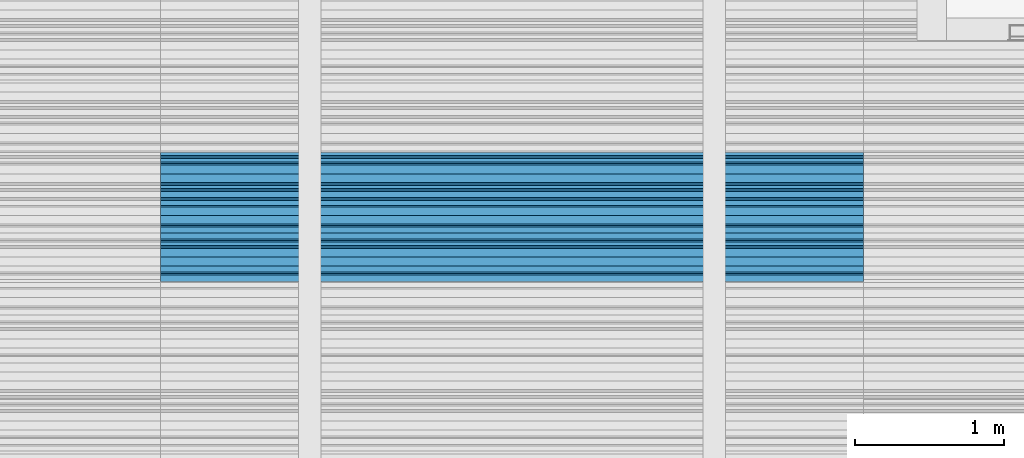
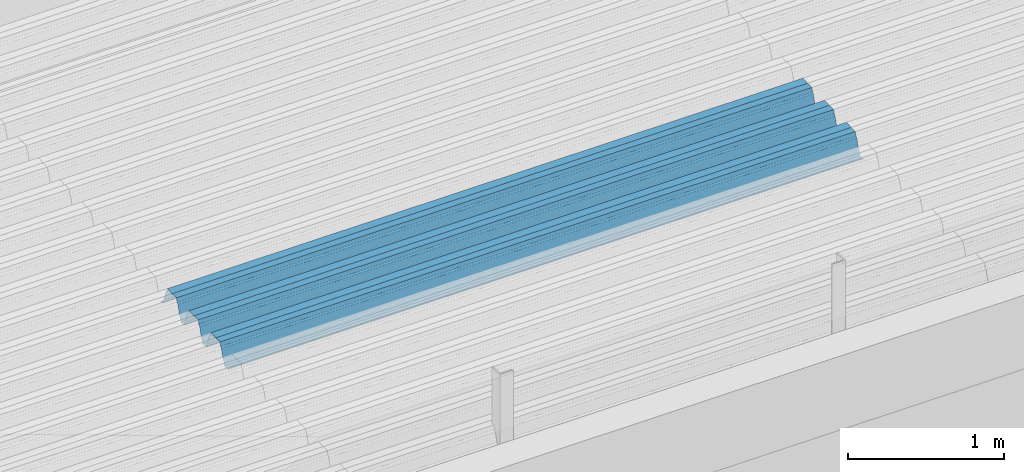
# One storey, part 32 of 153: 1 beam, 1 element without a shape of its own.
"""IFC2X3 building model written with IfcOpenShell, lengths in millimetres."""

from ifc_helpers import new_model, si_unit, frame, origin_with_axes, place, context, subcontext, project, spatial, faceted_brep, material, type_object, element, aggregate, save


model = new_model("IFC2X3")

# Units and contexts
model_context = context("Model", 3, precision=1e-05, world=origin_with_axes())
body_context = subcontext(model_context, "Body", "Model", "MODEL_VIEW")
ifc_project = project(units=[si_unit("LENGTHUNIT", "METRE", prefix="MILLI"), si_unit("AREAUNIT", "SQUARE_METRE"), si_unit("VOLUMEUNIT", "CUBIC_METRE"), si_unit("MASSUNIT", "GRAM", prefix="KILO"), si_unit("TIMEUNIT", "SECOND"), si_unit("PLANEANGLEUNIT", "RADIAN"), si_unit("SOLIDANGLEUNIT", "STERADIAN"), si_unit("THERMODYNAMICTEMPERATUREUNIT", "DEGREE_CELSIUS"), si_unit("LUMINOUSINTENSITYUNIT", "LUMEN")], contexts=[model_context])

# Site, building, storey
site_placement = place(None, origin_with_axes())
site = spatial("IfcSite", under=ifc_project, at=site_placement, CompositionType="ELEMENT")
building_placement = place(site_placement, origin_with_axes())
building = spatial("IfcBuilding", under=site, at=building_placement, CompositionType="ELEMENT")
storey_placement = place(building_placement, origin_with_axes())
storey = spatial("IfcBuildingStorey", under=building, at=storey_placement, Name="8", CompositionType="ELEMENT", Elevation=0.0)

# Assembly, beam
assembly_placement = place(storey_placement, origin_with_axes())
assembly = element("IfcElementAssembly", 1, at=assembly_placement, inside=storey, Name="Steel Assembly", AssemblyPlace="NOTDEFINED", PredefinedType="RIGID_FRAME")
ifc_material = material(Name="STEEL/S355J2")
beam_type = type_object("IfcBeamType", Name="W", PredefinedType="NOTDEFINED")
beam_placement = place(assembly_placement, frame((17251.9999999917, 17045.0793818646, 105770.64887313), z_axis=(0.0, -0.0124990270013869, 0.999921884110963), x_axis=(-1.0, 3.00000001838171e-08, 0.0)))
beam = element("IfcBeam", 2, at=beam_placement, type_object=beam_type, material=ifc_material, ObjectType="W", context=body_context, shape_type="Brep", body=[
    faceted_brep([(0.0, -412.839996337891, -77.0100021362159), (0.0, -409.160003662109, -77.0100021362014), (4717.0, -409.160003662109, -77.0100021362159), (4717.0, -412.839996337891, -77.0100021362159), (0.0, -408.070007324222, -73.4800033569045), (4717.0, -408.070007324222, -73.480003356919), (0.0, -400.339996337894, -48.0600013732619), (4717.0, -400.339996337894, -48.0600013732765), (0.0, -399.459991455082, -46.5600013732619), (4717.0, -399.459991455078, -46.5600013732765), (0.0, -390.329986572269, -36.5499992370314), (4717.0, -390.329986572266, -36.549999237046), (0.0, -389.19000244141, -34.6300010680861), (4717.0, -389.190002441403, -34.6300010681007), (0.0, -367.820007324222, 35.3400001526024), (4717.0, -367.820007324219, 35.3400001525879), (0.0, -366.989990234379, 36.8499984741502), (4717.0, -366.989990234375, 36.8499984741356), (0.0, -357.809997558597, 46.8600006103807), (4717.0, -357.809997558594, 46.8600006103661), (0.0, -356.720001220707, 48.7700004577782), (4717.0, -356.720001220703, 48.7700004577782), (0.0, -349.309997558594, 73.1500015258935), (4717.0, -349.309997558594, 73.1500015258935), (0.0, -347.850006103516, 75.2300033569481), (4717.0, -347.850006103516, 75.2300033569481), (0.0, -345.470001220707, 76.010002136245), (4717.0, -345.470001220703, 76.0100021362305), (0.0, -305.480010986332, 76.010002136245), (4717.0, -305.480010986324, 76.0100021362305), (0.0, -304.279998779301, 75.8000030517578), (4717.0, -304.279998779301, 75.8000030517724), (0.0, -291.679992675785, 71.6999969482567), (4717.0, -291.679992675785, 71.6999969482567), (0.0, -290.179992675789, 71.2300033569481), (4717.0, -290.179992675781, 71.2300033569481), (0.0, -288.720001220707, 71.6999969482567), (4717.0, -288.720001220703, 71.6999969482422), (0.0, -276.119995117191, 75.8000030517869), (4717.0, -276.119995117188, 75.8000030517724), (0.0, -274.929992675785, 76.010002136245), (4717.0, -274.929992675785, 76.010002136245), (0.0, -234.94000244141, 76.010002136245), (4717.0, -234.94000244141, 76.010002136245), (0.0, -232.550003051758, 75.2300033569627), (4717.0, -232.550003051758, 75.2300033569481), (0.0, -231.100006103519, 73.1500015258935), (4717.0, -231.100006103516, 73.1500015258789), (0.0, -223.679992675785, 48.7700004577782), (4717.0, -223.679992675781, 48.7700004577782), (0.0, -222.589996337894, 46.8600006103661), (4717.0, -222.589996337891, 46.8600006103516), (0.0, -213.410003662113, 36.8499984741502), (4717.0, -213.410003662109, 36.8499984741356), (0.0, -212.529998779301, 35.3400001526024), (4717.0, -212.529998779297, 35.3400001526024), (0.0, -191.160003662109, -34.6300010681007), (4717.0, -191.160003662109, -34.6300010681007), (0.0, -190.070007324222, -36.5499992370605), (4717.0, -190.070007324215, -36.549999237046), (0.0, -180.940002441406, -46.560001373291), (4717.0, -180.940002441406, -46.5600013732765), (0.0, -180.059997558597, -48.0600013732619), (4717.0, -180.059997558594, -48.0600013732765), (0.0, -172.330001831055, -73.480003356919), (4717.0, -172.330001831055, -73.480003356919), (0.0, -171.240005493168, -77.0100021362159), (4717.0, -171.240005493164, -77.0100021362159), (0.0, -129.330001831062, -77.0100021362014), (4717.0, -129.330001831055, -77.0100021362159), (0.0, -128.300003051761, -73.480003356919), (4717.0, -128.300003051758, -73.4800033569336), (0.0, -120.51999664307, -48.0600013732765), (4717.0, -120.519996643063, -48.0600013732765), (0.0, -119.629997253418, -46.5600013732765), (4717.0, -119.629997253418, -46.5600013732765), (0.0, -110.500000000004, -36.5499992370314), (4717.0, -110.5, -36.549999237046), (0.0, -109.419998168949, -34.6300010680861), (4717.0, -109.419998168945, -34.6300010681007), (0.0, -88.0500030517615, 35.3400001526024), (4717.0, -88.0500030517578, 35.3400001526024), (0.0, -87.160003662113, 36.8499984741356), (4717.0, -87.160003662113, 36.8499984741356), (0.0, -78.0400009155273, 46.8600006103807), (4717.0, -78.0400009155273, 46.8600006103661), (0.0, -76.8899993896557, 48.7700004577782), (4717.0, -76.8899993896521, 48.7700004577782), (0.0, -69.4800033569336, 73.1500015258935), (4717.0, -69.4800033569336, 73.1500015258935), (0.0, -68.0299987793042, 75.2300033569336), (4717.0, -68.0299987792969, 75.2300033569481), (0.0, -65.6399993896521, 76.010002136245), (4717.0, -65.6399993896484, 76.010002136245), (0.0, -25.6499996185375, 76.0100021362596), (4717.0, -25.6499996185303, 76.010002136245), (0.0, -24.5100002288891, 75.8000030517724), (4717.0, -24.5100002288818, 75.8000030517724), (0.0, -11.8500003814697, 71.6999969482567), (4717.0, -11.8500003814661, 71.6999969482567), (0.0, -10.3999996185339, 71.2300033569481), (4717.0, -10.3999996185303, 71.2300033569336), (0.0, -8.89999961853391, 71.6999969482567), (4717.0, -8.89999961853391, 71.6999969482567), (0.0, 3.71000003814333, 75.8000030517724), (4717.0, 3.71000003814697, 75.8000030517869), (0.0, 4.90000009536379, 76.0100021362596), (4717.0, 4.90000009536379, 76.010002136245), (0.0, 44.8899993896484, 76.010002136245), (4717.0, 44.8899993896484, 76.010002136245), (0.0, 47.2799987792932, 75.2300033569481), (4717.0, 47.2799987792969, 75.2300033569481), (0.0, 48.6800003051721, 73.1500015258935), (4717.0, 48.6800003051758, 73.1500015258789), (0.0, 56.1500015258753, 48.7700004577782), (4717.0, 56.1500015258789, 48.7700004577782), (0.0, 57.2400016784632, 46.8600006103807), (4717.0, 57.2400016784632, 46.8600006103661), (0.0, 66.3700027465784, 36.8499984741211), (4717.0, 66.3700027465857, 36.8499984741356), (0.0, 67.2499999999964, 35.3400001526024), (4717.0, 67.2500000000036, 35.3400001526024), (0.0, 88.6200027465748, -34.6300010681007), (4717.0, 88.620002746582, -34.6300010681152), (0.0, 89.709999084469, -36.549999237046), (4717.0, 89.7099990844727, -36.5499992370605), (0.0, 98.8899993896412, -46.5600013732765), (4717.0, 98.8899993896484, -46.5600013732765), (0.0, 99.7699966430628, -48.0600013732765), (4717.0, 99.7699966430664, -48.060001373291), (0.0, 107.499999999996, -73.4800033569336), (4717.0, 107.5, -73.480003356919), (0.0, 108.589996337887, -77.0100021362014), (4717.0, 108.589996337894, -77.0100021362159), (0.0, 112.269996643063, -77.0100021362159), (4717.0, 112.269996643066, -77.0100021362159), (0.0, 146.759994506836, -77.0100021362159), (4717.0, 146.759994506836, -77.0100021362159), (0.0, 150.440002441403, -77.0100021362159), (4717.0, 150.440002441403, -77.0100021362305), (0.0, 151.529998779297, -73.480003356919), (4717.0, 151.529998779297, -73.4800033569336), (0.0, 159.30999755859, -48.0600013732765), (4717.0, 159.309997558594, -48.0600013732765), (0.0, 160.190002441406, -46.5600013732619), (4717.0, 160.190002441406, -46.5600013732765), (0.0, 169.320007324215, -36.549999237046), (4717.0, 169.320007324222, -36.5499992370605), (0.0, 170.410003662106, -34.6300010680861), (4717.0, 170.410003662109, -34.6300010681007), (0.0, 191.779998779293, 35.3400001526024), (4717.0, 191.779998779293, 35.3400001526024), (0.0, 192.660003662109, 36.8499984741502), (4717.0, 192.660003662109, 36.8499984741356), (0.0, 201.789993286129, 46.8600006103661), (4717.0, 201.789993286133, 46.8600006103661), (0.0, 202.880004882809, 48.7700004577637), (4717.0, 202.880004882813, 48.7700004577782), (0.0, 210.350006103512, 73.150001525908), (4717.0, 210.350006103516, 73.1500015258935), (0.0, 211.800003051754, 75.2300033569481), (4717.0, 211.800003051758, 75.2300033569336), (0.0, 214.190002441406, 76.010002136245), (4717.0, 214.19000244141, 76.010002136245), (0.0, 254.179992675778, 76.010002136245), (4717.0, 254.179992675778, 76.010002136245), (0.0, 255.320007324215, 75.8000030517869), (4717.0, 255.320007324222, 75.8000030517724), (0.0, 267.980010986324, 71.6999969482713), (4717.0, 267.980010986328, 71.6999969482567), (0.0, 269.429992675778, 71.2300033569481), (4717.0, 269.429992675781, 71.2300033569481), (0.0, 270.880004882809, 71.6999969482567), (4717.0, 270.880004882813, 71.6999969482567), (0.0, 283.540008544918, 75.8000030517869), (4717.0, 283.540008544918, 75.8000030517724), (0.0, 284.679992675778, 76.010002136245), (4717.0, 284.679992675778, 76.010002136245), (0.0, 324.670013427731, 76.010002136245), (4717.0, 324.670013427738, 76.010002136245), (0.0, 327.049987792969, 75.2300033569627), (4717.0, 327.049987792969, 75.2300033569481), (0.0, 328.510009765625, 73.1500015258789), (4717.0, 328.510009765625, 73.1500015258935), (0.0, 335.980010986324, 48.7700004577782), (4717.0, 335.980010986328, 48.7700004577782), (0.0, 337.05999755859, 46.8600006103661), (4717.0, 337.059997558594, 46.8600006103516), (0.0, 346.190002441399, 36.8499984741356), (4717.0, 346.190002441406, 36.8499984741211), (0.0, 347.079986572266, 35.3400001526024), (4717.0, 347.079986572266, 35.3400001526024), (0.0, 368.450012207028, -34.6300010680861), (4717.0, 368.450012207035, -34.6300010681007), (0.0, 369.529998779293, -36.5499992370314), (4717.0, 369.529998779297, -36.549999237046), (0.0, 378.660003662106, -46.5600013732619), (4717.0, 378.660003662106, -46.5600013732765), (0.0, 379.540008544918, -48.0600013732619), (4717.0, 379.540008544922, -48.0600013732765), (0.0, 387.329986572262, -73.480003356919), (4717.0, 387.329986572266, -73.4800033569045), (0.0, 388.410003662109, -77.0100021362159), (4717.0, 388.410003662109, -77.0100021362159), (0.0, 392.100006103512, -77.0100021362159), (4717.0, 392.100006103519, -77.0100021362159), (0.0, 426.589996337887, -77.0100021362159), (4717.0, 426.589996337891, -77.0100021362159), (0.0, 430.269989013668, -77.0100021362159), (4717.0, 430.269989013672, -77.0100021362305), (0.0, 431.359985351559, -73.4800033569045), (4717.0, 431.359985351563, -73.480003356919), (0.0, 433.179992675778, -67.5699996948097), (4717.0, 433.179992675781, -67.5699996948097), (0.0, 432.220001220699, -67.2699966430373), (4717.0, 432.220001220703, -67.2699966430519), (0.0, 430.410003662106, -73.1800003051612), (4717.0, 430.410003662106, -73.1800003051758), (0.0, 429.529998779293, -76.0100021362159), (4717.0, 429.529998779293, -76.0100021362159), (0.0, 426.589996337891, -76.0100021362159), (4717.0, 426.589996337891, -76.0100021362159), (0.0, 392.100006103512, -76.0100021362159), (4717.0, 392.100006103516, -76.0100021362159), (0.0, 389.149993896481, -76.0100021362014), (4717.0, 389.149993896484, -76.0100021362159), (0.0, 388.279998779293, -73.1800003051467), (4717.0, 388.279998779301, -73.1800003051612), (0.0, 380.470001220699, -47.659999847383), (4717.0, 380.470001220703, -47.6599998473976), (0.0, 379.470001220699, -45.9599990844436), (4717.0, 379.470001220703, -45.9599990844581), (0.0, 370.350006103512, -35.9599990844581), (4717.0, 370.350006103519, -35.9599990844581), (0.0, 369.369995117184, -34.2299995422218), (4717.0, 369.369995117184, -34.2299995422218), (0.0, 347.999999999996, 35.7500000000146), (4717.0, 348.0, 35.7500000000146), (0.0, 346.999999999996, 37.4399986267235), (4717.0, 347.000000000004, 37.4399986267235), (0.0, 337.880004882809, 47.450000762954), (4717.0, 337.880004882809, 47.4500007629395), (0.0, 336.899993896481, 49.1699981689453), (4717.0, 336.899993896484, 49.1699981689599), (0.0, 329.420013427731, 73.5999984741356), (4717.0, 329.420013427734, 73.5999984741356), (0.0, 327.679992675781, 76.0699996948533), (4717.0, 327.679992675781, 76.0699996948388), (0.0, 324.829986572262, 77.010002136245), (4717.0, 324.829986572266, 77.0100021362305), (0.0, 284.589996337887, 77.010002136245), (4717.0, 284.589996337891, 77.010002136245), (0.0, 283.290008544922, 76.769996643081), (4717.0, 283.290008544922, 76.769996643081), (0.0, 270.570007324215, 72.6500015258935), (4717.0, 270.570007324219, 72.6500015258935), (0.0, 269.429992675781, 72.2799987793114), (4717.0, 269.429992675781, 72.2799987793114), (0.0, 268.279998779293, 72.650001525908), (4717.0, 268.279998779297, 72.6500015258935), (0.0, 255.570007324219, 76.769996643081), (4717.0, 255.570007324219, 76.769996643081), (0.0, 254.270004272461, 77.0100021362596), (4717.0, 254.270004272461, 77.010002136245), (0.0, 214.029998779293, 77.0100021362596), (4717.0, 214.029998779297, 77.010002136245), (0.0, 211.179992675781, 76.0699996948388), (4717.0, 211.179992675781, 76.0699996948533), (0.0, 209.440002441403, 73.5999984741356), (4717.0, 209.44000244141, 73.5999984741211), (0.0, 201.960006713864, 49.1699981689599), (4717.0, 201.960006713867, 49.1699981689453), (0.0, 200.979995727532, 47.450000762954), (4717.0, 200.979995727539, 47.4500007629395), (0.0, 191.850006103508, 37.4399986267235), (4717.0, 191.850006103516, 37.439998626709), (0.0, 190.860000610352, 35.7500000000146), (4717.0, 190.860000610352, 35.75), (0.0, 169.49000549316, -34.2299995422218), (4717.0, 169.49000549316, -34.2299995422363), (0.0, 168.509994506832, -35.9599990844581), (4717.0, 168.509994506836, -35.9599990844581), (0.0, 159.380004882805, -45.9599990844436), (4717.0, 159.380004882813, -45.9599990844581), (0.0, 158.389999389645, -47.6599998473976), (4717.0, 158.389999389645, -47.6599998474121), (0.0, 150.580001831051, -73.1800003051612), (4717.0, 150.580001831058, -73.1800003051758), (0.0, 149.710006713864, -76.0100021362159), (4717.0, 149.710006713867, -76.0100021362159), (0.0, 146.759994506836, -76.0100021362159), (4717.0, 146.759994506836, -76.0100021362159), (0.0, 112.269996643063, -76.0100021362159), (4717.0, 112.269996643063, -76.0100021362159), (0.0, 109.319999694821, -76.0100021362159), (4717.0, 109.319999694821, -76.0100021362159), (0.0, 108.449996948239, -73.1900024413917), (4717.0, 108.449996948242, -73.1900024414063), (0.0, 100.690002441406, -47.659999847383), (4717.0, 100.69000244141, -47.6599998473976), (0.0, 99.6999969482386, -45.9599990844581), (4717.0, 99.6999969482422, -45.9599990844581), (0.0, 90.5199966430664, -35.9599990844581), (4717.0, 90.5199966430664, -35.9599990844727), (0.0, 89.5400009155273, -34.2299995422218), (4717.0, 89.5400009155273, -34.2299995422218), (0.0, 68.1699981689417, 35.7500000000146), (4717.0, 68.1699981689453, 35.7500000000146), (0.0, 67.1699981689417, 37.4399986267235), (4717.0, 67.1699981689453, 37.4399986267235), (0.0, 58.0499992370569, 47.4500007629686), (4717.0, 58.0499992370605, 47.450000762954), (0.0, 57.0699996948206, 49.1699981689599), (4717.0, 57.0699996948279, 49.1699981689453), (0.0, 49.5900001525843, 73.5899963379052), (4717.0, 49.5900001525879, 73.5899963378906), (0.0, 47.9099998474085, 76.0699996948388), (4717.0, 47.9099998474121, 76.0699996948242), (0.0, 45.0499992370569, 77.010002136245), (4717.0, 45.0499992370605, 77.010002136245), (0.0, 4.82000017165774, 77.010002136245), (4717.0, 4.82000017166138, 77.010002136245), (0.0, 3.47000002860659, 76.7699966430955), (4717.0, 3.47000002860659, 76.769996643081), (0.0, -9.19999980926514, 72.6500015258935), (4717.0, -9.19999980926514, 72.6500015258789), (0.0, -10.3900003433264, 72.2799987792969), (4717.0, -10.3900003433228, 72.2799987793114), (0.0, -11.5399999618567, 72.6500015258935), (4717.0, -11.5399999618494, 72.6500015258935), (0.0, -24.2600002288855, 76.769996643081), (4717.0, -24.2600002288818, 76.769996643081), (0.0, -25.559999465946, 77.0100021362596), (4717.0, -25.5599994659424, 77.010002136245), (0.0, -65.8000030517615, 77.0100021362596), (4717.0, -65.8000030517578, 77.010002136245), (0.0, -68.6500015258862, 76.0699996948533), (4717.0, -68.6500015258825, 76.0699996948388), (0.0, -70.3899993896521, 73.5999984741356), (4717.0, -70.3899993896484, 73.5999984741211), (0.0, -77.8199996948242, 49.1800003051903), (4717.0, -77.8199996948242, 49.1800003051903), (0.0, -78.8399963378943, 47.450000762954), (4717.0, -78.8399963378906, 47.4500007629395), (0.0, -87.9700012207031, 37.4399986267235), (4717.0, -87.9700012207031, 37.4399986267235), (0.0, -88.9700012207068, 35.7500000000146), (4717.0, -88.9700012207031, 35.75), (0.0, -110.339996337894, -34.2299995422218), (4717.0, -110.339996337887, -34.2299995422218), (0.0, -111.319999694828, -35.9599990844581), (4717.0, -111.319999694824, -35.9599990844581), (0.0, -120.440002441406, -45.9599990844436), (4717.0, -120.440002441406, -45.9599990844581), (0.0, -121.44000244141, -47.6599998473976), (4717.0, -121.440002441403, -47.6599998473976), (0.0, -129.250000000004, -73.1900024413771), (4717.0, -129.25, -73.1900024413917), (0.0, -130.080001831062, -76.0100021362159), (4717.0, -130.080001831055, -76.0100021362159), (0.0, -170.5, -76.0100021362014), (4717.0, -170.5, -76.0100021362159), (0.0, -171.380004882816, -73.1900024413917), (4717.0, -171.380004882813, -73.1900024414063), (0.0, -179.139999389652, -47.6599998473976), (4717.0, -179.139999389648, -47.6599998473976), (0.0, -180.130004882816, -45.9599990844581), (4717.0, -180.130004882813, -45.9599990844581), (0.0, -189.259994506836, -35.9599990844581), (4717.0, -189.259994506832, -35.9599990844581), (0.0, -190.240005493168, -34.2299995422218), (4717.0, -190.240005493164, -34.2299995422218), (0.0, -211.610000610355, 35.7500000000146), (4717.0, -211.610000610352, 35.7500000000146), (0.0, -212.600006103519, 37.4399986267381), (4717.0, -212.600006103519, 37.4399986267235), (0.0, -221.779998779301, 47.450000762954), (4717.0, -221.779998779293, 47.4500007629395), (0.0, -222.75999450684, 49.1699981689599), (4717.0, -222.759994506836, 49.1699981689599), (0.0, -230.190002441406, 73.5999984741356), (4717.0, -230.190002441406, 73.5999984741211), (0.0, -231.919998168945, 76.0699996948388), (4717.0, -231.919998168945, 76.0699996948388), (0.0, -234.779998779301, 77.010002136245), (4717.0, -234.779998779293, 77.010002136245), (0.0, -275.010009765629, 77.010002136245), (4717.0, -275.010009765625, 77.0100021362305), (0.0, -276.359985351563, 76.769996643081), (4717.0, -276.359985351563, 76.7699966430664), (0.0, -289.029998779297, 72.6500015258789), (4717.0, -289.029998779297, 72.6500015258935), (0.0, -290.179992675785, 72.2799987793114), (4717.0, -290.179992675785, 72.2799987793114), (0.0, -291.380004882816, 72.650001525908), (4717.0, -291.380004882813, 72.6500015258935), (0.0, -304.040008544926, 76.769996643081), (4717.0, -304.040008544918, 76.769996643081), (0.0, -305.390014648441, 77.010002136245), (4717.0, -305.390014648438, 77.010002136245), (0.0, -345.63000488282, 77.0100021362596), (4717.0, -345.630004882813, 77.010002136245), (0.0, -348.480010986332, 76.0699996948388), (4717.0, -348.480010986324, 76.0699996948388), (0.0, -350.220001220707, 73.5999984741356), (4717.0, -350.220001220703, 73.5999984741211), (0.0, -357.649993896492, 49.1699981689599), (4717.0, -357.649993896484, 49.1699981689744), (0.0, -358.63000488282, 47.450000762954), (4717.0, -358.630004882813, 47.450000762954), (0.0, -367.809997558594, 37.4300003051903), (4717.0, -367.809997558594, 37.4300003051903), (0.0, -368.750000000004, 35.7299995422654), (4717.0, -368.75, 35.7299995422509), (0.0, -390.109985351566, -34.2200012207031), (4717.0, -390.109985351563, -34.2200012206886), (0.0, -391.140014648441, -35.9500007629249), (4717.0, -391.140014648438, -35.9500007629103), (0.0, -400.269989013676, -45.9599990844436), (4717.0, -400.269989013672, -45.9599990844581), (0.0, -401.269989013672, -47.6599998473976), (4717.0, -401.269989013672, -47.6599998473976), (0.0, -409.029998779297, -73.1900024413917), (4717.0, -409.029998779297, -73.1900024413917), (0.0, -409.899993896488, -76.0100021362159), (4717.0, -409.899993896481, -76.0100021362305), (0.0, -412.839996337891, -76.0100021362159), (4717.0, -412.839996337891, -76.0100021362305), (0.0, -433.179992675785, -76.0100021362159), (4717.0, -433.179992675781, -76.0100021362159), (0.0, -433.179992675785, -77.0100021362159), (4717.0, -433.179992675785, -77.0100021362305)], [[[0, 1, 2, 3]], [[1, 4, 5, 2]], [[4, 6, 7, 5]], [[6, 8, 9, 7]], [[8, 10, 11, 9]], [[10, 12, 13, 11]], [[12, 14, 15, 13]], [[14, 16, 17, 15]], [[16, 18, 19, 17]], [[18, 20, 21, 19]], [[20, 22, 23, 21]], [[22, 24, 25, 23]], [[24, 26, 27, 25]], [[26, 28, 29, 27]], [[28, 30, 31, 29]], [[30, 32, 33, 31]], [[32, 34, 35, 33]], [[34, 36, 37, 35]], [[36, 38, 39, 37]], [[38, 40, 41, 39]], [[40, 42, 43, 41]], [[42, 44, 45, 43]], [[44, 46, 47, 45]], [[46, 48, 49, 47]], [[48, 50, 51, 49]], [[50, 52, 53, 51]], [[52, 54, 55, 53]], [[54, 56, 57, 55]], [[56, 58, 59, 57]], [[58, 60, 61, 59]], [[60, 62, 63, 61]], [[62, 64, 65, 63]], [[64, 66, 67, 65]], [[66, 68, 69, 67]], [[68, 70, 71, 69]], [[70, 72, 73, 71]], [[72, 74, 75, 73]], [[74, 76, 77, 75]], [[76, 78, 79, 77]], [[78, 80, 81, 79]], [[80, 82, 83, 81]], [[82, 84, 85, 83]], [[84, 86, 87, 85]], [[86, 88, 89, 87]], [[88, 90, 91, 89]], [[90, 92, 93, 91]], [[92, 94, 95, 93]], [[94, 96, 97, 95]], [[96, 98, 99, 97]], [[98, 100, 101, 99]], [[100, 102, 103, 101]], [[102, 104, 105, 103]], [[104, 106, 107, 105]], [[106, 108, 109, 107]], [[108, 110, 111, 109]], [[110, 112, 113, 111]], [[112, 114, 115, 113]], [[114, 116, 117, 115]], [[116, 118, 119, 117]], [[118, 120, 121, 119]], [[120, 122, 123, 121]], [[122, 124, 125, 123]], [[124, 126, 127, 125]], [[126, 128, 129, 127]], [[128, 130, 131, 129]], [[130, 132, 133, 131]], [[132, 134, 135, 133]], [[134, 136, 137, 135]], [[136, 138, 139, 137]], [[138, 140, 141, 139]], [[140, 142, 143, 141]], [[142, 144, 145, 143]], [[144, 146, 147, 145]], [[146, 148, 149, 147]], [[148, 150, 151, 149]], [[150, 152, 153, 151]], [[152, 154, 155, 153]], [[154, 156, 157, 155]], [[156, 158, 159, 157]], [[158, 160, 161, 159]], [[160, 162, 163, 161]], [[162, 164, 165, 163]], [[164, 166, 167, 165]], [[166, 168, 169, 167]], [[168, 170, 171, 169]], [[170, 172, 173, 171]], [[172, 174, 175, 173]], [[174, 176, 177, 175]], [[176, 178, 179, 177]], [[178, 180, 181, 179]], [[180, 182, 183, 181]], [[182, 184, 185, 183]], [[184, 186, 187, 185]], [[186, 188, 189, 187]], [[188, 190, 191, 189]], [[190, 192, 193, 191]], [[192, 194, 195, 193]], [[194, 196, 197, 195]], [[196, 198, 199, 197]], [[198, 200, 201, 199]], [[200, 202, 203, 201]], [[202, 204, 205, 203]], [[204, 206, 207, 205]], [[206, 208, 209, 207]], [[208, 210, 211, 209]], [[210, 212, 213, 211]], [[212, 214, 215, 213]], [[214, 216, 217, 215]], [[216, 218, 219, 217]], [[218, 220, 221, 219]], [[220, 222, 223, 221]], [[222, 224, 225, 223]], [[224, 226, 227, 225]], [[226, 228, 229, 227]], [[228, 230, 231, 229]], [[230, 232, 233, 231]], [[232, 234, 235, 233]], [[234, 236, 237, 235]], [[236, 238, 239, 237]], [[238, 240, 241, 239]], [[240, 242, 243, 241]], [[242, 244, 245, 243]], [[244, 246, 247, 245]], [[246, 248, 249, 247]], [[248, 250, 251, 249]], [[250, 252, 253, 251]], [[252, 254, 255, 253]], [[254, 256, 257, 255]], [[256, 258, 259, 257]], [[258, 260, 261, 259]], [[260, 262, 263, 261]], [[262, 264, 265, 263]], [[264, 266, 267, 265]], [[266, 268, 269, 267]], [[268, 270, 271, 269]], [[270, 272, 273, 271]], [[272, 274, 275, 273]], [[274, 276, 277, 275]], [[276, 278, 279, 277]], [[278, 280, 281, 279]], [[280, 282, 283, 281]], [[282, 284, 285, 283]], [[284, 286, 287, 285]], [[286, 288, 289, 287]], [[288, 290, 291, 289]], [[290, 292, 293, 291]], [[292, 294, 295, 293]], [[294, 296, 297, 295]], [[296, 298, 299, 297]], [[298, 300, 301, 299]], [[300, 302, 303, 301]], [[302, 304, 305, 303]], [[304, 306, 307, 305]], [[306, 308, 309, 307]], [[308, 310, 311, 309]], [[310, 312, 313, 311]], [[312, 314, 315, 313]], [[314, 316, 317, 315]], [[316, 318, 319, 317]], [[318, 320, 321, 319]], [[320, 322, 323, 321]], [[322, 324, 325, 323]], [[324, 326, 327, 325]], [[326, 328, 329, 327]], [[328, 330, 331, 329]], [[330, 332, 333, 331]], [[332, 334, 335, 333]], [[334, 336, 337, 335]], [[336, 338, 339, 337]], [[338, 340, 341, 339]], [[340, 342, 343, 341]], [[342, 344, 345, 343]], [[344, 346, 347, 345]], [[346, 348, 349, 347]], [[348, 350, 351, 349]], [[350, 352, 353, 351]], [[352, 354, 355, 353]], [[354, 356, 357, 355]], [[356, 358, 359, 357]], [[358, 360, 361, 359]], [[360, 362, 363, 361]], [[362, 364, 365, 363]], [[364, 366, 367, 365]], [[366, 368, 369, 367]], [[368, 370, 371, 369]], [[370, 372, 373, 371]], [[372, 374, 375, 373]], [[374, 376, 377, 375]], [[376, 378, 379, 377]], [[378, 380, 381, 379]], [[380, 382, 383, 381]], [[382, 384, 385, 383]], [[384, 386, 387, 385]], [[386, 388, 389, 387]], [[388, 390, 391, 389]], [[390, 392, 393, 391]], [[392, 394, 395, 393]], [[394, 396, 397, 395]], [[396, 398, 399, 397]], [[398, 400, 401, 399]], [[400, 402, 403, 401]], [[402, 404, 405, 403]], [[404, 406, 407, 405]], [[406, 408, 409, 407]], [[408, 410, 411, 409]], [[410, 412, 413, 411]], [[412, 414, 415, 413]], [[414, 416, 417, 415]], [[416, 418, 419, 417]], [[418, 420, 421, 419]], [[420, 422, 423, 421]], [[422, 424, 425, 423]], [[424, 426, 427, 425]], [[426, 428, 429, 427]], [[428, 430, 431, 429]], [[430, 0, 3, 431]], [[5, 7, 9, 11, 13, 15, 17, 19, 21, 23, 25, 27, 29, 31, 33, 35, 37, 39, 41, 43, 45, 47, 49, 51, 53, 55, 57, 59, 61, 63, 65, 67, 69, 71, 73, 75, 77, 79, 81, 83, 85, 87, 89, 91, 93, 95, 97, 99, 101, 103, 105, 107, 109, 111, 113, 115, 117, 119, 121, 123, 125, 127, 129, 131, 133, 135, 137, 139, 141, 143, 145, 147, 149, 151, 153, 155, 157, 159, 161, 163, 165, 167, 169, 171, 173, 175, 177, 179, 181, 183, 185, 187, 189, 191, 193, 195, 197, 199, 201, 203, 205, 207, 209, 211, 213, 215, 217, 219, 221, 223, 225, 227, 229, 231, 233, 235, 237, 239, 241, 243, 245, 247, 249, 251, 253, 255, 257, 259, 261, 263, 265, 267, 269, 271, 273, 275, 277, 279, 281, 283, 285, 287, 289, 291, 293, 295, 297, 299, 301, 303, 305, 307, 309, 311, 313, 315, 317, 319, 321, 323, 325, 327, 329, 331, 333, 335, 337, 339, 341, 343, 345, 347, 349, 351, 353, 355, 357, 359, 361, 363, 365, 367, 369, 371, 373, 375, 377, 379, 381, 383, 385, 387, 389, 391, 393, 395, 397, 399, 401, 403, 405, 407, 409, 411, 413, 415, 417, 419, 421, 423, 425, 427, 429, 431, 3, 2]], [[430, 428, 426, 424, 422, 420, 418, 416, 414, 412, 410, 408, 406, 404, 402, 400, 398, 396, 394, 392, 390, 388, 386, 384, 382, 380, 378, 376, 374, 372, 370, 368, 366, 364, 362, 360, 358, 356, 354, 352, 350, 348, 346, 344, 342, 340, 338, 336, 334, 332, 330, 328, 326, 324, 322, 320, 318, 316, 314, 312, 310, 308, 306, 304, 302, 300, 298, 296, 294, 292, 290, 288, 286, 284, 282, 280, 278, 276, 274, 272, 270, 268, 266, 264, 262, 260, 258, 256, 254, 252, 250, 248, 246, 244, 242, 240, 238, 236, 234, 232, 230, 228, 226, 224, 222, 220, 218, 216, 214, 212, 210, 208, 206, 204, 202, 200, 198, 196, 194, 192, 190, 188, 186, 184, 182, 180, 178, 176, 174, 172, 170, 168, 166, 164, 162, 160, 158, 156, 154, 152, 150, 148, 146, 144, 142, 140, 138, 136, 134, 132, 130, 128, 126, 124, 122, 120, 118, 116, 114, 112, 110, 108, 106, 104, 102, 100, 98, 96, 94, 92, 90, 88, 86, 84, 82, 80, 78, 76, 74, 72, 70, 68, 66, 64, 62, 60, 58, 56, 54, 52, 50, 48, 46, 44, 42, 40, 38, 36, 34, 32, 30, 28, 26, 24, 22, 20, 18, 16, 14, 12, 10, 8, 6, 4, 1, 0]]]),
])
aggregate(assembly, [beam])

save(model, "model.ifc")
